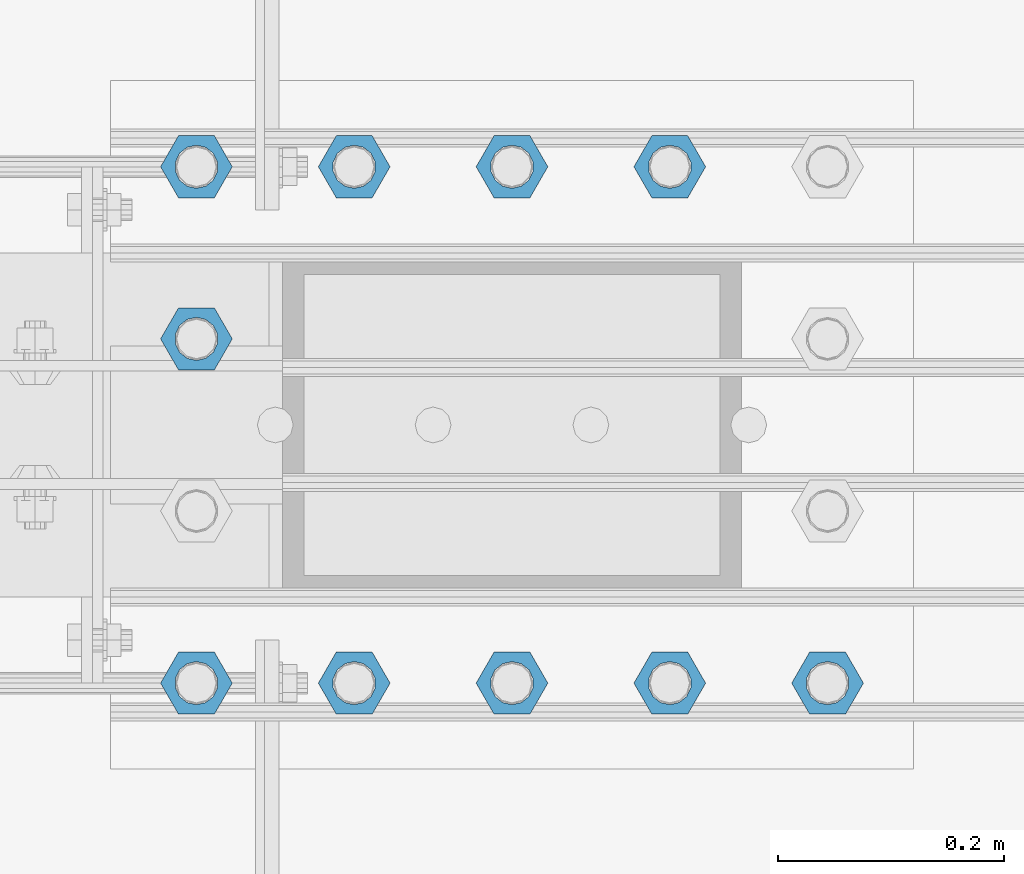
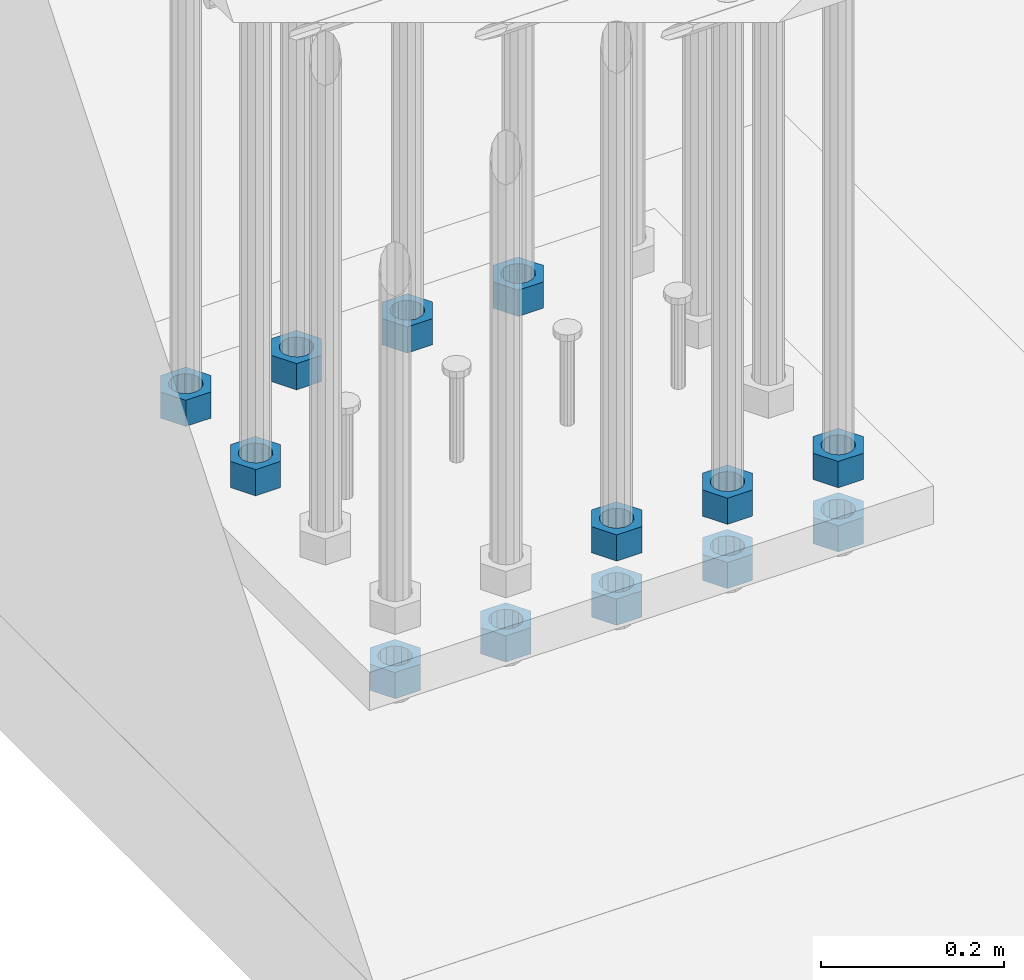
# One storey, part 1376 of 1876: 13 beams, 1 element without a shape of its own.
"""IFC2X3 building model written with IfcOpenShell, lengths in millimetres."""

from ifc_helpers import new_model, si_unit, frame, origin_with_axes, place, context, subcontext, project, spatial, faceted_brep, material, type_object, element, aggregate, save


model = new_model("IFC2X3")

# Units and contexts
model_context = context("Model", 3, precision=1e-05, world=origin_with_axes())
body_context = subcontext(model_context, "Body", "Model", "MODEL_VIEW")
ifc_project = project(units=[si_unit("LENGTHUNIT", "METRE", prefix="MILLI"), si_unit("AREAUNIT", "SQUARE_METRE"), si_unit("VOLUMEUNIT", "CUBIC_METRE"), si_unit("MASSUNIT", "GRAM", prefix="KILO"), si_unit("TIMEUNIT", "SECOND"), si_unit("PLANEANGLEUNIT", "RADIAN"), si_unit("SOLIDANGLEUNIT", "STERADIAN"), si_unit("THERMODYNAMICTEMPERATUREUNIT", "DEGREE_CELSIUS"), si_unit("LUMINOUSINTENSITYUNIT", "LUMEN")], contexts=[model_context])

# Site, building, storey
site_placement = place(None, origin_with_axes())
site = spatial("IfcSite", under=ifc_project, at=site_placement, CompositionType="ELEMENT")
building_placement = place(site_placement, origin_with_axes())
building = spatial("IfcBuilding", under=site, at=building_placement, Name="Undefined", CompositionType="ELEMENT")
storey_placement = place(building_placement, origin_with_axes())
storey = spatial("IfcBuildingStorey", under=building, at=storey_placement, Name="Undefined", CompositionType="ELEMENT", Elevation=0.0)

# Assembly, beams
assembly_placement = place(storey_placement, origin_with_axes())
assembly = element("IfcElementAssembly", 1, at=assembly_placement, inside=storey, Name="PLATE", AssemblyPlace="NOTDEFINED", PredefinedType="RIGID_FRAME")
ifc_material = material(Name="STEEL/A563")
beam_type = type_object("IfcBeamType", Name="1-3/8_HEAVY_HEX_NUT", PredefinedType="NOTDEFINED")
beam_1_placement = place(assembly_placement, frame((371.474990844727, -10541.0, -701.675000762939), z_axis=(0.0, -1.0, 0.0), x_axis=(0.0, 0.0, -1.0)))
beam_1 = element("IfcBeam", 2, at=beam_1_placement, type_object=beam_type, material=ifc_material, Name="NUT", ObjectType="1-3/8_HEAVY_HEX_NUT", context=body_context, shape_type="Brep", body=[
    faceted_brep([(0.0, -31.75, 0.0), (0.0, -15.8800001144409, -27.5), (34.925, -15.8800001144409, -27.5), (34.925, -31.75, 0.0), (0.0, 15.8800001144409, -27.5), (34.925, 15.8800001144409, -27.5), (0.0, 31.75, 0.0), (34.925, 31.75, 0.0), (0.0, 15.8800001144409, 27.5), (34.925, 15.8800001144409, 27.5), (0.0, -15.8800001144409, 27.5), (34.925, -15.8800001144409, 27.5), (0.0, 0.0, 19.0499999999993), (0.0, 8.2654848991624, 17.1634562461559), (34.925, 8.26548489916252, 17.163456246155), (34.925, 0.0, 19.0499992370605), (0.0, 14.8938891445259, 11.8774802497237), (34.925, 14.8938891445259, 11.8774802497246), (0.0, 18.5723759832526, 4.2390236220981), (34.925, 18.5723759832528, 4.23902362209628), (0.0, 18.5723759832526, -4.2390236220981), (34.925, 18.5723759832528, -4.23902362209628), (0.0, 14.8938891445259, -11.8774802497237), (34.925, 14.8938891445259, -11.8774802497246), (0.0, 8.2654848991624, -17.1634562461568), (34.925, 8.26548489916252, -17.163456246155), (0.0, 0.0, -19.05), (34.925, 0.0, -19.0499992370605), (0.0, -8.2654848991624, -17.1634562461559), (34.925, -8.26548489916252, -17.163456246155), (0.0, -14.8938891445259, -11.8774802497237), (34.925, -14.8938891445259, -11.8774802497246), (0.0, -18.5723759832526, -4.2390236220981), (34.925, -18.5723759832528, -4.23902362209628), (0.0, -18.5723759832526, 4.2390236220981), (34.925, -18.5723759832528, 4.23902362209628), (0.0, -14.8938891445259, 11.8774802497237), (34.925, -14.8938891445259, 11.8774802497246), (0.0, -8.2654848991624, 17.1634562461568), (34.925, -8.26548489916252, 17.163456246155)], [[[0, 1, 2, 3]], [[1, 4, 5, 2]], [[4, 6, 7, 5]], [[6, 8, 9, 7]], [[8, 10, 11, 9]], [[10, 0, 3, 11]], [[12, 13, 14, 15]], [[13, 16, 17, 14]], [[16, 18, 19, 17]], [[18, 20, 21, 19]], [[20, 22, 23, 21]], [[22, 24, 25, 23]], [[24, 26, 27, 25]], [[26, 28, 29, 27]], [[28, 30, 31, 29]], [[30, 32, 33, 31]], [[32, 34, 35, 33]], [[34, 36, 37, 35]], [[36, 38, 39, 37]], [[38, 12, 15, 39]], [[5, 7, 9, 11, 3, 2], [17, 19, 21, 23, 25, 27, 29, 31, 33, 35, 37, 39, 15, 14]], [[10, 8, 6, 4, 1, 0], [38, 36, 34, 32, 30, 28, 26, 24, 22, 20, 18, 16, 13, 12]]]),
])
beam_2_placement = place(assembly_placement, frame((231.774990844727, -10541.0, -701.675000762939), z_axis=(0.0, -1.0, 0.0), x_axis=(0.0, 0.0, -1.0)))
beam_2 = element("IfcBeam", 3, at=beam_2_placement, type_object=beam_type, material=ifc_material, Name="NUT", ObjectType="1-3/8_HEAVY_HEX_NUT", context=body_context, shape_type="Brep", body=[
    faceted_brep([(0.0, -31.75, 0.0), (0.0, -15.8800001144409, -27.5), (34.925, -15.8800001144409, -27.5), (34.925, -31.75, 0.0), (0.0, 15.8800001144409, -27.5), (34.925, 15.8800001144409, -27.5), (0.0, 31.75, 0.0), (34.925, 31.75, 0.0), (0.0, 15.8800001144409, 27.5), (34.925, 15.8800001144409, 27.5), (0.0, -15.8800001144409, 27.5), (34.925, -15.8800001144409, 27.5), (0.0, 0.0, 19.0499999999993), (0.0, 8.2654848991624, 17.1634562461559), (34.925, 8.26548489916252, 17.163456246155), (34.925, 0.0, 19.0499992370605), (0.0, 14.8938891445259, 11.8774802497237), (34.925, 14.8938891445259, 11.8774802497246), (0.0, 18.5723759832526, 4.2390236220981), (34.925, 18.5723759832528, 4.23902362209628), (0.0, 18.5723759832526, -4.2390236220981), (34.925, 18.5723759832528, -4.23902362209628), (0.0, 14.8938891445259, -11.8774802497237), (34.925, 14.8938891445259, -11.8774802497246), (0.0, 8.2654848991624, -17.1634562461568), (34.925, 8.26548489916252, -17.163456246155), (0.0, 0.0, -19.05), (34.925, 0.0, -19.0499992370605), (0.0, -8.2654848991624, -17.1634562461559), (34.925, -8.26548489916252, -17.163456246155), (0.0, -14.8938891445259, -11.8774802497237), (34.925, -14.8938891445259, -11.8774802497246), (0.0, -18.5723759832526, -4.2390236220981), (34.925, -18.5723759832528, -4.23902362209628), (0.0, -18.5723759832526, 4.2390236220981), (34.925, -18.5723759832528, 4.23902362209628), (0.0, -14.8938891445259, 11.8774802497237), (34.925, -14.8938891445259, 11.8774802497246), (0.0, -8.2654848991624, 17.1634562461568), (34.925, -8.26548489916252, 17.163456246155)], [[[0, 1, 2, 3]], [[1, 4, 5, 2]], [[4, 6, 7, 5]], [[6, 8, 9, 7]], [[8, 10, 11, 9]], [[10, 0, 3, 11]], [[12, 13, 14, 15]], [[13, 16, 17, 14]], [[16, 18, 19, 17]], [[18, 20, 21, 19]], [[20, 22, 23, 21]], [[22, 24, 25, 23]], [[24, 26, 27, 25]], [[26, 28, 29, 27]], [[28, 30, 31, 29]], [[30, 32, 33, 31]], [[32, 34, 35, 33]], [[34, 36, 37, 35]], [[36, 38, 39, 37]], [[38, 12, 15, 39]], [[5, 7, 9, 11, 3, 2], [17, 19, 21, 23, 25, 27, 29, 31, 33, 35, 37, 39, 15, 14]], [[10, 8, 6, 4, 1, 0], [38, 36, 34, 32, 30, 28, 26, 24, 22, 20, 18, 16, 13, 12]]]),
])
beam_3_placement = place(assembly_placement, frame((92.0749908447272, -10541.0, -701.675000762939), z_axis=(0.0, -1.0, 0.0), x_axis=(0.0, 0.0, -1.0)))
beam_3 = element("IfcBeam", 4, at=beam_3_placement, type_object=beam_type, material=ifc_material, Name="NUT", ObjectType="1-3/8_HEAVY_HEX_NUT", context=body_context, shape_type="Brep", body=[
    faceted_brep([(0.0, -31.75, 0.0), (0.0, -15.8800001144409, -27.5), (34.925, -15.8800001144409, -27.5), (34.925, -31.75, 0.0), (0.0, 15.8800001144409, -27.5), (34.925, 15.8800001144409, -27.5), (0.0, 31.75, 0.0), (34.925, 31.75, 0.0), (0.0, 15.8800001144409, 27.5), (34.925, 15.8800001144409, 27.5), (0.0, -15.8800001144409, 27.5), (34.925, -15.8800001144409, 27.5), (0.0, 0.0, 19.0499999999993), (0.0, 8.2654848991624, 17.1634562461559), (34.925, 8.26548489916252, 17.163456246155), (34.925, 0.0, 19.0499992370605), (0.0, 14.8938891445259, 11.8774802497237), (34.925, 14.8938891445259, 11.8774802497246), (0.0, 18.5723759832526, 4.2390236220981), (34.925, 18.5723759832528, 4.23902362209628), (0.0, 18.5723759832526, -4.2390236220981), (34.925, 18.5723759832528, -4.23902362209628), (0.0, 14.8938891445259, -11.8774802497237), (34.925, 14.8938891445259, -11.8774802497246), (0.0, 8.2654848991624, -17.1634562461568), (34.925, 8.26548489916252, -17.163456246155), (0.0, 0.0, -19.05), (34.925, 0.0, -19.0499992370605), (0.0, -8.2654848991624, -17.1634562461559), (34.925, -8.26548489916252, -17.163456246155), (0.0, -14.8938891445259, -11.8774802497237), (34.925, -14.8938891445259, -11.8774802497246), (0.0, -18.5723759832526, -4.2390236220981), (34.925, -18.5723759832528, -4.23902362209628), (0.0, -18.5723759832526, 4.2390236220981), (34.925, -18.5723759832528, 4.23902362209628), (0.0, -14.8938891445259, 11.8774802497237), (34.925, -14.8938891445259, 11.8774802497246), (0.0, -8.2654848991624, 17.1634562461568), (34.925, -8.26548489916252, 17.163456246155)], [[[0, 1, 2, 3]], [[1, 4, 5, 2]], [[4, 6, 7, 5]], [[6, 8, 9, 7]], [[8, 10, 11, 9]], [[10, 0, 3, 11]], [[12, 13, 14, 15]], [[13, 16, 17, 14]], [[16, 18, 19, 17]], [[18, 20, 21, 19]], [[20, 22, 23, 21]], [[22, 24, 25, 23]], [[24, 26, 27, 25]], [[26, 28, 29, 27]], [[28, 30, 31, 29]], [[30, 32, 33, 31]], [[32, 34, 35, 33]], [[34, 36, 37, 35]], [[36, 38, 39, 37]], [[38, 12, 15, 39]], [[5, 7, 9, 11, 3, 2], [17, 19, 21, 23, 25, 27, 29, 31, 33, 35, 37, 39, 15, 14]], [[10, 8, 6, 4, 1, 0], [38, 36, 34, 32, 30, 28, 26, 24, 22, 20, 18, 16, 13, 12]]]),
])
beam_4_placement = place(assembly_placement, frame((-47.6250091552728, -10541.0, -701.675000762939), z_axis=(0.0, -1.0, 0.0), x_axis=(0.0, 0.0, -1.0)))
beam_4 = element("IfcBeam", 5, at=beam_4_placement, type_object=beam_type, material=ifc_material, Name="NUT", ObjectType="1-3/8_HEAVY_HEX_NUT", context=body_context, shape_type="Brep", body=[
    faceted_brep([(0.0, -31.75, 0.0), (0.0, -15.8800001144409, -27.5), (34.925, -15.8800001144409, -27.5), (34.925, -31.75, 0.0), (0.0, 15.8800001144409, -27.5), (34.925, 15.8800001144409, -27.5), (0.0, 31.75, 0.0), (34.925, 31.75, 0.0), (0.0, 15.8800001144409, 27.5), (34.925, 15.8800001144409, 27.5), (0.0, -15.8800001144409, 27.5), (34.925, -15.8800001144409, 27.5), (0.0, 0.0, 19.0499999999993), (0.0, 8.2654848991624, 17.1634562461559), (34.925, 8.26548489916252, 17.163456246155), (34.925, 0.0, 19.0499992370605), (0.0, 14.8938891445259, 11.8774802497237), (34.925, 14.8938891445259, 11.8774802497246), (0.0, 18.5723759832526, 4.2390236220981), (34.925, 18.5723759832528, 4.23902362209628), (0.0, 18.5723759832526, -4.2390236220981), (34.925, 18.5723759832528, -4.23902362209628), (0.0, 14.8938891445259, -11.8774802497237), (34.925, 14.8938891445259, -11.8774802497246), (0.0, 8.2654848991624, -17.1634562461568), (34.925, 8.26548489916252, -17.163456246155), (0.0, 0.0, -19.05), (34.925, 0.0, -19.0499992370605), (0.0, -8.2654848991624, -17.1634562461559), (34.925, -8.26548489916252, -17.163456246155), (0.0, -14.8938891445259, -11.8774802497237), (34.925, -14.8938891445259, -11.8774802497246), (0.0, -18.5723759832526, -4.2390236220981), (34.925, -18.5723759832528, -4.23902362209628), (0.0, -18.5723759832526, 4.2390236220981), (34.925, -18.5723759832528, 4.23902362209628), (0.0, -14.8938891445259, 11.8774802497237), (34.925, -14.8938891445259, 11.8774802497246), (0.0, -8.2654848991624, 17.1634562461568), (34.925, -8.26548489916252, 17.163456246155)], [[[0, 1, 2, 3]], [[1, 4, 5, 2]], [[4, 6, 7, 5]], [[6, 8, 9, 7]], [[8, 10, 11, 9]], [[10, 0, 3, 11]], [[12, 13, 14, 15]], [[13, 16, 17, 14]], [[16, 18, 19, 17]], [[18, 20, 21, 19]], [[20, 22, 23, 21]], [[22, 24, 25, 23]], [[24, 26, 27, 25]], [[26, 28, 29, 27]], [[28, 30, 31, 29]], [[30, 32, 33, 31]], [[32, 34, 35, 33]], [[34, 36, 37, 35]], [[36, 38, 39, 37]], [[38, 12, 15, 39]], [[5, 7, 9, 11, 3, 2], [17, 19, 21, 23, 25, 27, 29, 31, 33, 35, 37, 39, 15, 14]], [[10, 8, 6, 4, 1, 0], [38, 36, 34, 32, 30, 28, 26, 24, 22, 20, 18, 16, 13, 12]]]),
])
beam_5_placement = place(assembly_placement, frame((-47.6250091552728, -10693.399991862, -701.675000762939), z_axis=(0.0, -1.0, 0.0), x_axis=(0.0, 0.0, -1.0)))
beam_5 = element("IfcBeam", 6, at=beam_5_placement, type_object=beam_type, material=ifc_material, Name="NUT", ObjectType="1-3/8_HEAVY_HEX_NUT", context=body_context, shape_type="Brep", body=[
    faceted_brep([(0.0, -31.75, 0.0), (0.0, -15.8800001144409, -27.5), (34.925, -15.8800001144409, -27.5), (34.925, -31.75, 0.0), (0.0, 15.8800001144409, -27.5), (34.925, 15.8800001144409, -27.5), (0.0, 31.75, 0.0), (34.925, 31.75, 0.0), (0.0, 15.8800001144409, 27.5), (34.925, 15.8800001144409, 27.5), (0.0, -15.8800001144409, 27.5), (34.925, -15.8800001144409, 27.5), (0.0, 0.0, 19.0499999999993), (0.0, 8.2654848991624, 17.1634562461559), (34.925, 8.26548489916252, 17.163456246155), (34.925, 0.0, 19.0499992370605), (0.0, 14.8938891445259, 11.8774802497237), (34.925, 14.8938891445259, 11.8774802497246), (0.0, 18.5723759832526, 4.2390236220981), (34.925, 18.5723759832528, 4.23902362209628), (0.0, 18.5723759832526, -4.2390236220981), (34.925, 18.5723759832528, -4.23902362209628), (0.0, 14.8938891445259, -11.8774802497237), (34.925, 14.8938891445259, -11.8774802497246), (0.0, 8.2654848991624, -17.1634562461568), (34.925, 8.26548489916252, -17.163456246155), (0.0, 0.0, -19.05), (34.925, 0.0, -19.0499992370605), (0.0, -8.2654848991624, -17.1634562461559), (34.925, -8.26548489916252, -17.163456246155), (0.0, -14.8938891445259, -11.8774802497237), (34.925, -14.8938891445259, -11.8774802497246), (0.0, -18.5723759832526, -4.2390236220981), (34.925, -18.5723759832528, -4.23902362209628), (0.0, -18.5723759832526, 4.2390236220981), (34.925, -18.5723759832528, 4.23902362209628), (0.0, -14.8938891445259, 11.8774802497237), (34.925, -14.8938891445259, 11.8774802497246), (0.0, -8.2654848991624, 17.1634562461568), (34.925, -8.26548489916252, 17.163456246155)], [[[0, 1, 2, 3]], [[1, 4, 5, 2]], [[4, 6, 7, 5]], [[6, 8, 9, 7]], [[8, 10, 11, 9]], [[10, 0, 3, 11]], [[12, 13, 14, 15]], [[13, 16, 17, 14]], [[16, 18, 19, 17]], [[18, 20, 21, 19]], [[20, 22, 23, 21]], [[22, 24, 25, 23]], [[24, 26, 27, 25]], [[26, 28, 29, 27]], [[28, 30, 31, 29]], [[30, 32, 33, 31]], [[32, 34, 35, 33]], [[34, 36, 37, 35]], [[36, 38, 39, 37]], [[38, 12, 15, 39]], [[5, 7, 9, 11, 3, 2], [17, 19, 21, 23, 25, 27, 29, 31, 33, 35, 37, 39, 15, 14]], [[10, 8, 6, 4, 1, 0], [38, 36, 34, 32, 30, 28, 26, 24, 22, 20, 18, 16, 13, 12]]]),
])
beam_6_placement = place(assembly_placement, frame((231.774990844727, -10998.1999755859, -701.675000762939), z_axis=(0.0, -1.0, 0.0), x_axis=(0.0, 0.0, -1.0)))
beam_6 = element("IfcBeam", 7, at=beam_6_placement, type_object=beam_type, material=ifc_material, Name="NUT", ObjectType="1-3/8_HEAVY_HEX_NUT", context=body_context, shape_type="Brep", body=[
    faceted_brep([(0.0, -31.75, 0.0), (0.0, -15.8800001144409, -27.5), (34.925, -15.8800001144409, -27.5), (34.925, -31.75, 0.0), (0.0, 15.8800001144409, -27.5), (34.925, 15.8800001144409, -27.5), (0.0, 31.75, 0.0), (34.925, 31.75, 0.0), (0.0, 15.8800001144409, 27.5), (34.925, 15.8800001144409, 27.5), (0.0, -15.8800001144409, 27.5), (34.925, -15.8800001144409, 27.5), (0.0, 0.0, 19.0499999999993), (0.0, 8.2654848991624, 17.1634562461559), (34.925, 8.26548489916252, 17.163456246155), (34.925, 0.0, 19.0499992370605), (0.0, 14.8938891445259, 11.8774802497237), (34.925, 14.8938891445259, 11.8774802497246), (0.0, 18.5723759832526, 4.2390236220981), (34.925, 18.5723759832528, 4.23902362209628), (0.0, 18.5723759832526, -4.2390236220981), (34.925, 18.5723759832528, -4.23902362209628), (0.0, 14.8938891445259, -11.8774802497237), (34.925, 14.8938891445259, -11.8774802497246), (0.0, 8.2654848991624, -17.1634562461568), (34.925, 8.26548489916252, -17.163456246155), (0.0, 0.0, -19.05), (34.925, 0.0, -19.0499992370605), (0.0, -8.2654848991624, -17.1634562461559), (34.925, -8.26548489916252, -17.163456246155), (0.0, -14.8938891445259, -11.8774802497237), (34.925, -14.8938891445259, -11.8774802497246), (0.0, -18.5723759832526, -4.2390236220981), (34.925, -18.5723759832528, -4.23902362209628), (0.0, -18.5723759832526, 4.2390236220981), (34.925, -18.5723759832528, 4.23902362209628), (0.0, -14.8938891445259, 11.8774802497237), (34.925, -14.8938891445259, 11.8774802497246), (0.0, -8.2654848991624, 17.1634562461568), (34.925, -8.26548489916252, 17.163456246155)], [[[0, 1, 2, 3]], [[1, 4, 5, 2]], [[4, 6, 7, 5]], [[6, 8, 9, 7]], [[8, 10, 11, 9]], [[10, 0, 3, 11]], [[12, 13, 14, 15]], [[13, 16, 17, 14]], [[16, 18, 19, 17]], [[18, 20, 21, 19]], [[20, 22, 23, 21]], [[22, 24, 25, 23]], [[24, 26, 27, 25]], [[26, 28, 29, 27]], [[28, 30, 31, 29]], [[30, 32, 33, 31]], [[32, 34, 35, 33]], [[34, 36, 37, 35]], [[36, 38, 39, 37]], [[38, 12, 15, 39]], [[5, 7, 9, 11, 3, 2], [17, 19, 21, 23, 25, 27, 29, 31, 33, 35, 37, 39, 15, 14]], [[10, 8, 6, 4, 1, 0], [38, 36, 34, 32, 30, 28, 26, 24, 22, 20, 18, 16, 13, 12]]]),
])
beam_7_placement = place(assembly_placement, frame((371.474990844727, -10998.1999755859, -701.675000762939), z_axis=(0.0, -1.0, 0.0), x_axis=(0.0, 0.0, -1.0)))
beam_7 = element("IfcBeam", 8, at=beam_7_placement, type_object=beam_type, material=ifc_material, Name="NUT", ObjectType="1-3/8_HEAVY_HEX_NUT", context=body_context, shape_type="Brep", body=[
    faceted_brep([(0.0, -31.75, 0.0), (0.0, -15.8800001144409, -27.5), (34.925, -15.8800001144409, -27.5), (34.925, -31.75, 0.0), (0.0, 15.8800001144409, -27.5), (34.925, 15.8800001144409, -27.5), (0.0, 31.75, 0.0), (34.925, 31.75, 0.0), (0.0, 15.8800001144409, 27.5), (34.925, 15.8800001144409, 27.5), (0.0, -15.8800001144409, 27.5), (34.925, -15.8800001144409, 27.5), (0.0, 0.0, 19.0499999999993), (0.0, 8.2654848991624, 17.1634562461559), (34.925, 8.26548489916252, 17.163456246155), (34.925, 0.0, 19.0499992370605), (0.0, 14.8938891445259, 11.8774802497237), (34.925, 14.8938891445259, 11.8774802497246), (0.0, 18.5723759832526, 4.2390236220981), (34.925, 18.5723759832528, 4.23902362209628), (0.0, 18.5723759832526, -4.2390236220981), (34.925, 18.5723759832528, -4.23902362209628), (0.0, 14.8938891445259, -11.8774802497237), (34.925, 14.8938891445259, -11.8774802497246), (0.0, 8.2654848991624, -17.1634562461568), (34.925, 8.26548489916252, -17.163456246155), (0.0, 0.0, -19.05), (34.925, 0.0, -19.0499992370605), (0.0, -8.2654848991624, -17.1634562461559), (34.925, -8.26548489916252, -17.163456246155), (0.0, -14.8938891445259, -11.8774802497237), (34.925, -14.8938891445259, -11.8774802497246), (0.0, -18.5723759832526, -4.2390236220981), (34.925, -18.5723759832528, -4.23902362209628), (0.0, -18.5723759832526, 4.2390236220981), (34.925, -18.5723759832528, 4.23902362209628), (0.0, -14.8938891445259, 11.8774802497237), (34.925, -14.8938891445259, 11.8774802497246), (0.0, -8.2654848991624, 17.1634562461568), (34.925, -8.26548489916252, 17.163456246155)], [[[0, 1, 2, 3]], [[1, 4, 5, 2]], [[4, 6, 7, 5]], [[6, 8, 9, 7]], [[8, 10, 11, 9]], [[10, 0, 3, 11]], [[12, 13, 14, 15]], [[13, 16, 17, 14]], [[16, 18, 19, 17]], [[18, 20, 21, 19]], [[20, 22, 23, 21]], [[22, 24, 25, 23]], [[24, 26, 27, 25]], [[26, 28, 29, 27]], [[28, 30, 31, 29]], [[30, 32, 33, 31]], [[32, 34, 35, 33]], [[34, 36, 37, 35]], [[36, 38, 39, 37]], [[38, 12, 15, 39]], [[5, 7, 9, 11, 3, 2], [17, 19, 21, 23, 25, 27, 29, 31, 33, 35, 37, 39, 15, 14]], [[10, 8, 6, 4, 1, 0], [38, 36, 34, 32, 30, 28, 26, 24, 22, 20, 18, 16, 13, 12]]]),
])
beam_8_placement = place(assembly_placement, frame((511.175003051758, -10998.1999755859, -701.675000762939), z_axis=(0.0, -1.0, 0.0), x_axis=(0.0, 0.0, -1.0)))
beam_8 = element("IfcBeam", 9, at=beam_8_placement, type_object=beam_type, material=ifc_material, Name="NUT", ObjectType="1-3/8_HEAVY_HEX_NUT", context=body_context, shape_type="Brep", body=[
    faceted_brep([(0.0, -31.75, 0.0), (0.0, -15.8800001144409, -27.5), (34.925, -15.8800001144409, -27.5), (34.925, -31.75, 0.0), (0.0, 15.8800001144409, -27.5), (34.925, 15.8800001144409, -27.5), (0.0, 31.75, 0.0), (34.925, 31.75, 0.0), (0.0, 15.8800001144409, 27.5), (34.925, 15.8800001144409, 27.5), (0.0, -15.8800001144409, 27.5), (34.925, -15.8800001144409, 27.5), (0.0, 0.0, 19.0499999999993), (0.0, 8.2654848991624, 17.1634562461559), (34.925, 8.26548489916252, 17.163456246155), (34.925, 0.0, 19.0499992370605), (0.0, 14.8938891445259, 11.8774802497237), (34.925, 14.8938891445259, 11.8774802497246), (0.0, 18.5723759832526, 4.2390236220981), (34.925, 18.5723759832528, 4.23902362209628), (0.0, 18.5723759832526, -4.2390236220981), (34.925, 18.5723759832528, -4.23902362209628), (0.0, 14.8938891445259, -11.8774802497237), (34.925, 14.8938891445259, -11.8774802497246), (0.0, 8.2654848991624, -17.1634562461568), (34.925, 8.26548489916252, -17.163456246155), (0.0, 0.0, -19.05), (34.925, 0.0, -19.0499992370605), (0.0, -8.2654848991624, -17.1634562461559), (34.925, -8.26548489916252, -17.163456246155), (0.0, -14.8938891445259, -11.8774802497237), (34.925, -14.8938891445259, -11.8774802497246), (0.0, -18.5723759832526, -4.2390236220981), (34.925, -18.5723759832528, -4.23902362209628), (0.0, -18.5723759832526, 4.2390236220981), (34.925, -18.5723759832528, 4.23902362209628), (0.0, -14.8938891445259, 11.8774802497237), (34.925, -14.8938891445259, 11.8774802497246), (0.0, -8.2654848991624, 17.1634562461568), (34.925, -8.26548489916252, 17.163456246155)], [[[0, 1, 2, 3]], [[1, 4, 5, 2]], [[4, 6, 7, 5]], [[6, 8, 9, 7]], [[8, 10, 11, 9]], [[10, 0, 3, 11]], [[12, 13, 14, 15]], [[13, 16, 17, 14]], [[16, 18, 19, 17]], [[18, 20, 21, 19]], [[20, 22, 23, 21]], [[22, 24, 25, 23]], [[24, 26, 27, 25]], [[26, 28, 29, 27]], [[28, 30, 31, 29]], [[30, 32, 33, 31]], [[32, 34, 35, 33]], [[34, 36, 37, 35]], [[36, 38, 39, 37]], [[38, 12, 15, 39]], [[5, 7, 9, 11, 3, 2], [17, 19, 21, 23, 25, 27, 29, 31, 33, 35, 37, 39, 15, 14]], [[10, 8, 6, 4, 1, 0], [38, 36, 34, 32, 30, 28, 26, 24, 22, 20, 18, 16, 13, 12]]]),
])
beam_9_placement = place(assembly_placement, frame((-47.625012207031, -10998.1999755859, -787.4), z_axis=(0.0, -1.0, 0.0), x_axis=(0.0, 0.0, -1.0)))
beam_9 = element("IfcBeam", 10, at=beam_9_placement, type_object=beam_type, material=ifc_material, Name="NUT", ObjectType="1-3/8_HEAVY_HEX_NUT", context=body_context, shape_type="Brep", body=[
    faceted_brep([(0.0, -31.75, 0.0), (0.0, -15.8800001144409, -27.5), (34.925, -15.8800001144409, -27.5), (34.925, -31.75, 0.0), (0.0, 15.8800001144409, -27.5), (34.925, 15.8800001144409, -27.5), (0.0, 31.75, 0.0), (34.925, 31.75, 0.0), (0.0, 15.8800001144409, 27.5), (34.925, 15.8800001144409, 27.5), (0.0, -15.8800001144409, 27.5), (34.925, -15.8800001144409, 27.5), (0.0, 0.0, 19.0499999999993), (0.0, 8.2654848991624, 17.1634562461559), (34.925, 8.26548489916252, 17.163456246155), (34.925, 0.0, 19.0499992370605), (0.0, 14.8938891445259, 11.8774802497237), (34.925, 14.8938891445259, 11.8774802497246), (0.0, 18.5723759832526, 4.2390236220981), (34.925, 18.5723759832528, 4.23902362209628), (0.0, 18.5723759832526, -4.2390236220981), (34.925, 18.5723759832528, -4.23902362209628), (0.0, 14.8938891445259, -11.8774802497237), (34.925, 14.8938891445259, -11.8774802497246), (0.0, 8.2654848991624, -17.1634562461568), (34.925, 8.26548489916252, -17.163456246155), (0.0, 0.0, -19.05), (34.925, 0.0, -19.0499992370605), (0.0, -8.2654848991624, -17.1634562461559), (34.925, -8.26548489916252, -17.163456246155), (0.0, -14.8938891445259, -11.8774802497237), (34.925, -14.8938891445259, -11.8774802497246), (0.0, -18.5723759832526, -4.2390236220981), (34.925, -18.5723759832528, -4.23902362209628), (0.0, -18.5723759832526, 4.2390236220981), (34.925, -18.5723759832528, 4.23902362209628), (0.0, -14.8938891445259, 11.8774802497237), (34.925, -14.8938891445259, 11.8774802497246), (0.0, -8.2654848991624, 17.1634562461568), (34.925, -8.26548489916252, 17.163456246155)], [[[0, 1, 2, 3]], [[1, 4, 5, 2]], [[4, 6, 7, 5]], [[6, 8, 9, 7]], [[8, 10, 11, 9]], [[10, 0, 3, 11]], [[12, 13, 14, 15]], [[13, 16, 17, 14]], [[16, 18, 19, 17]], [[18, 20, 21, 19]], [[20, 22, 23, 21]], [[22, 24, 25, 23]], [[24, 26, 27, 25]], [[26, 28, 29, 27]], [[28, 30, 31, 29]], [[30, 32, 33, 31]], [[32, 34, 35, 33]], [[34, 36, 37, 35]], [[36, 38, 39, 37]], [[38, 12, 15, 39]], [[5, 7, 9, 11, 3, 2], [17, 19, 21, 23, 25, 27, 29, 31, 33, 35, 37, 39, 15, 14]], [[10, 8, 6, 4, 1, 0], [38, 36, 34, 32, 30, 28, 26, 24, 22, 20, 18, 16, 13, 12]]]),
])
beam_10_placement = place(assembly_placement, frame((92.074987792969, -10998.1999755859, -787.4), z_axis=(0.0, -1.0, 0.0), x_axis=(0.0, 0.0, -1.0)))
beam_10 = element("IfcBeam", 11, at=beam_10_placement, type_object=beam_type, material=ifc_material, Name="NUT", ObjectType="1-3/8_HEAVY_HEX_NUT", context=body_context, shape_type="Brep", body=[
    faceted_brep([(0.0, -31.75, 0.0), (0.0, -15.8800001144409, -27.5), (34.925, -15.8800001144409, -27.5), (34.925, -31.75, 0.0), (0.0, 15.8800001144409, -27.5), (34.925, 15.8800001144409, -27.5), (0.0, 31.75, 0.0), (34.925, 31.75, 0.0), (0.0, 15.8800001144409, 27.5), (34.925, 15.8800001144409, 27.5), (0.0, -15.8800001144409, 27.5), (34.925, -15.8800001144409, 27.5), (0.0, 0.0, 19.0499999999993), (0.0, 8.2654848991624, 17.1634562461559), (34.925, 8.26548489916252, 17.163456246155), (34.925, 0.0, 19.0499992370605), (0.0, 14.8938891445259, 11.8774802497237), (34.925, 14.8938891445259, 11.8774802497246), (0.0, 18.5723759832526, 4.2390236220981), (34.925, 18.5723759832528, 4.23902362209628), (0.0, 18.5723759832526, -4.2390236220981), (34.925, 18.5723759832528, -4.23902362209628), (0.0, 14.8938891445259, -11.8774802497237), (34.925, 14.8938891445259, -11.8774802497246), (0.0, 8.2654848991624, -17.1634562461568), (34.925, 8.26548489916252, -17.163456246155), (0.0, 0.0, -19.05), (34.925, 0.0, -19.0499992370605), (0.0, -8.2654848991624, -17.1634562461559), (34.925, -8.26548489916252, -17.163456246155), (0.0, -14.8938891445259, -11.8774802497237), (34.925, -14.8938891445259, -11.8774802497246), (0.0, -18.5723759832526, -4.2390236220981), (34.925, -18.5723759832528, -4.23902362209628), (0.0, -18.5723759832526, 4.2390236220981), (34.925, -18.5723759832528, 4.23902362209628), (0.0, -14.8938891445259, 11.8774802497237), (34.925, -14.8938891445259, 11.8774802497246), (0.0, -8.2654848991624, 17.1634562461568), (34.925, -8.26548489916252, 17.163456246155)], [[[0, 1, 2, 3]], [[1, 4, 5, 2]], [[4, 6, 7, 5]], [[6, 8, 9, 7]], [[8, 10, 11, 9]], [[10, 0, 3, 11]], [[12, 13, 14, 15]], [[13, 16, 17, 14]], [[16, 18, 19, 17]], [[18, 20, 21, 19]], [[20, 22, 23, 21]], [[22, 24, 25, 23]], [[24, 26, 27, 25]], [[26, 28, 29, 27]], [[28, 30, 31, 29]], [[30, 32, 33, 31]], [[32, 34, 35, 33]], [[34, 36, 37, 35]], [[36, 38, 39, 37]], [[38, 12, 15, 39]], [[5, 7, 9, 11, 3, 2], [17, 19, 21, 23, 25, 27, 29, 31, 33, 35, 37, 39, 15, 14]], [[10, 8, 6, 4, 1, 0], [38, 36, 34, 32, 30, 28, 26, 24, 22, 20, 18, 16, 13, 12]]]),
])
beam_11_placement = place(assembly_placement, frame((231.774987792969, -10998.1999755859, -787.4), z_axis=(0.0, -1.0, 0.0), x_axis=(0.0, 0.0, -1.0)))
beam_11 = element("IfcBeam", 12, at=beam_11_placement, type_object=beam_type, material=ifc_material, Name="NUT", ObjectType="1-3/8_HEAVY_HEX_NUT", context=body_context, shape_type="Brep", body=[
    faceted_brep([(0.0, -31.75, 0.0), (0.0, -15.8800001144409, -27.5), (34.925, -15.8800001144409, -27.5), (34.925, -31.75, 0.0), (0.0, 15.8800001144409, -27.5), (34.925, 15.8800001144409, -27.5), (0.0, 31.75, 0.0), (34.925, 31.75, 0.0), (0.0, 15.8800001144409, 27.5), (34.925, 15.8800001144409, 27.5), (0.0, -15.8800001144409, 27.5), (34.925, -15.8800001144409, 27.5), (0.0, 0.0, 19.0499999999993), (0.0, 8.2654848991624, 17.1634562461559), (34.925, 8.26548489916252, 17.163456246155), (34.925, 0.0, 19.0499992370605), (0.0, 14.8938891445259, 11.8774802497237), (34.925, 14.8938891445259, 11.8774802497246), (0.0, 18.5723759832526, 4.2390236220981), (34.925, 18.5723759832528, 4.23902362209628), (0.0, 18.5723759832526, -4.2390236220981), (34.925, 18.5723759832528, -4.23902362209628), (0.0, 14.8938891445259, -11.8774802497237), (34.925, 14.8938891445259, -11.8774802497246), (0.0, 8.2654848991624, -17.1634562461568), (34.925, 8.26548489916252, -17.163456246155), (0.0, 0.0, -19.05), (34.925, 0.0, -19.0499992370605), (0.0, -8.2654848991624, -17.1634562461559), (34.925, -8.26548489916252, -17.163456246155), (0.0, -14.8938891445259, -11.8774802497237), (34.925, -14.8938891445259, -11.8774802497246), (0.0, -18.5723759832526, -4.2390236220981), (34.925, -18.5723759832528, -4.23902362209628), (0.0, -18.5723759832526, 4.2390236220981), (34.925, -18.5723759832528, 4.23902362209628), (0.0, -14.8938891445259, 11.8774802497237), (34.925, -14.8938891445259, 11.8774802497246), (0.0, -8.2654848991624, 17.1634562461568), (34.925, -8.26548489916252, 17.163456246155)], [[[0, 1, 2, 3]], [[1, 4, 5, 2]], [[4, 6, 7, 5]], [[6, 8, 9, 7]], [[8, 10, 11, 9]], [[10, 0, 3, 11]], [[12, 13, 14, 15]], [[13, 16, 17, 14]], [[16, 18, 19, 17]], [[18, 20, 21, 19]], [[20, 22, 23, 21]], [[22, 24, 25, 23]], [[24, 26, 27, 25]], [[26, 28, 29, 27]], [[28, 30, 31, 29]], [[30, 32, 33, 31]], [[32, 34, 35, 33]], [[34, 36, 37, 35]], [[36, 38, 39, 37]], [[38, 12, 15, 39]], [[5, 7, 9, 11, 3, 2], [17, 19, 21, 23, 25, 27, 29, 31, 33, 35, 37, 39, 15, 14]], [[10, 8, 6, 4, 1, 0], [38, 36, 34, 32, 30, 28, 26, 24, 22, 20, 18, 16, 13, 12]]]),
])
beam_12_placement = place(assembly_placement, frame((371.474987792969, -10998.1999755859, -787.4), z_axis=(0.0, -1.0, 0.0), x_axis=(0.0, 0.0, -1.0)))
beam_12 = element("IfcBeam", 13, at=beam_12_placement, type_object=beam_type, material=ifc_material, Name="NUT", ObjectType="1-3/8_HEAVY_HEX_NUT", context=body_context, shape_type="Brep", body=[
    faceted_brep([(0.0, -31.75, 0.0), (0.0, -15.8800001144409, -27.5), (34.925, -15.8800001144409, -27.5), (34.925, -31.75, 0.0), (0.0, 15.8800001144409, -27.5), (34.925, 15.8800001144409, -27.5), (0.0, 31.75, 0.0), (34.925, 31.75, 0.0), (0.0, 15.8800001144409, 27.5), (34.925, 15.8800001144409, 27.5), (0.0, -15.8800001144409, 27.5), (34.925, -15.8800001144409, 27.5), (0.0, 0.0, 19.0499999999993), (0.0, 8.2654848991624, 17.1634562461559), (34.925, 8.26548489916252, 17.163456246155), (34.925, 0.0, 19.0499992370605), (0.0, 14.8938891445259, 11.8774802497237), (34.925, 14.8938891445259, 11.8774802497246), (0.0, 18.5723759832526, 4.2390236220981), (34.925, 18.5723759832528, 4.23902362209628), (0.0, 18.5723759832526, -4.2390236220981), (34.925, 18.5723759832528, -4.23902362209628), (0.0, 14.8938891445259, -11.8774802497237), (34.925, 14.8938891445259, -11.8774802497246), (0.0, 8.2654848991624, -17.1634562461568), (34.925, 8.26548489916252, -17.163456246155), (0.0, 0.0, -19.05), (34.925, 0.0, -19.0499992370605), (0.0, -8.2654848991624, -17.1634562461559), (34.925, -8.26548489916252, -17.163456246155), (0.0, -14.8938891445259, -11.8774802497237), (34.925, -14.8938891445259, -11.8774802497246), (0.0, -18.5723759832526, -4.2390236220981), (34.925, -18.5723759832528, -4.23902362209628), (0.0, -18.5723759832526, 4.2390236220981), (34.925, -18.5723759832528, 4.23902362209628), (0.0, -14.8938891445259, 11.8774802497237), (34.925, -14.8938891445259, 11.8774802497246), (0.0, -8.2654848991624, 17.1634562461568), (34.925, -8.26548489916252, 17.163456246155)], [[[0, 1, 2, 3]], [[1, 4, 5, 2]], [[4, 6, 7, 5]], [[6, 8, 9, 7]], [[8, 10, 11, 9]], [[10, 0, 3, 11]], [[12, 13, 14, 15]], [[13, 16, 17, 14]], [[16, 18, 19, 17]], [[18, 20, 21, 19]], [[20, 22, 23, 21]], [[22, 24, 25, 23]], [[24, 26, 27, 25]], [[26, 28, 29, 27]], [[28, 30, 31, 29]], [[30, 32, 33, 31]], [[32, 34, 35, 33]], [[34, 36, 37, 35]], [[36, 38, 39, 37]], [[38, 12, 15, 39]], [[5, 7, 9, 11, 3, 2], [17, 19, 21, 23, 25, 27, 29, 31, 33, 35, 37, 39, 15, 14]], [[10, 8, 6, 4, 1, 0], [38, 36, 34, 32, 30, 28, 26, 24, 22, 20, 18, 16, 13, 12]]]),
])
beam_13_placement = place(assembly_placement, frame((511.175, -10998.1999755859, -787.4), z_axis=(0.0, -1.0, 0.0), x_axis=(0.0, 0.0, -1.0)))
beam_13 = element("IfcBeam", 14, at=beam_13_placement, type_object=beam_type, material=ifc_material, Name="NUT", ObjectType="1-3/8_HEAVY_HEX_NUT", context=body_context, shape_type="Brep", body=[
    faceted_brep([(0.0, -31.75, 0.0), (0.0, -15.8800001144409, -27.5), (34.925, -15.8800001144409, -27.5), (34.925, -31.75, 0.0), (0.0, 15.8800001144409, -27.5), (34.925, 15.8800001144409, -27.5), (0.0, 31.75, 0.0), (34.925, 31.75, 0.0), (0.0, 15.8800001144409, 27.5), (34.925, 15.8800001144409, 27.5), (0.0, -15.8800001144409, 27.5), (34.925, -15.8800001144409, 27.5), (0.0, 0.0, 19.0499999999993), (0.0, 8.2654848991624, 17.1634562461559), (34.925, 8.26548489916252, 17.163456246155), (34.925, 0.0, 19.0499992370605), (0.0, 14.8938891445259, 11.8774802497237), (34.925, 14.8938891445259, 11.8774802497246), (0.0, 18.5723759832526, 4.2390236220981), (34.925, 18.5723759832528, 4.23902362209628), (0.0, 18.5723759832526, -4.2390236220981), (34.925, 18.5723759832528, -4.23902362209628), (0.0, 14.8938891445259, -11.8774802497237), (34.925, 14.8938891445259, -11.8774802497246), (0.0, 8.2654848991624, -17.1634562461568), (34.925, 8.26548489916252, -17.163456246155), (0.0, 0.0, -19.05), (34.925, 0.0, -19.0499992370605), (0.0, -8.2654848991624, -17.1634562461559), (34.925, -8.26548489916252, -17.163456246155), (0.0, -14.8938891445259, -11.8774802497237), (34.925, -14.8938891445259, -11.8774802497246), (0.0, -18.5723759832526, -4.2390236220981), (34.925, -18.5723759832528, -4.23902362209628), (0.0, -18.5723759832526, 4.2390236220981), (34.925, -18.5723759832528, 4.23902362209628), (0.0, -14.8938891445259, 11.8774802497237), (34.925, -14.8938891445259, 11.8774802497246), (0.0, -8.2654848991624, 17.1634562461568), (34.925, -8.26548489916252, 17.163456246155)], [[[0, 1, 2, 3]], [[1, 4, 5, 2]], [[4, 6, 7, 5]], [[6, 8, 9, 7]], [[8, 10, 11, 9]], [[10, 0, 3, 11]], [[12, 13, 14, 15]], [[13, 16, 17, 14]], [[16, 18, 19, 17]], [[18, 20, 21, 19]], [[20, 22, 23, 21]], [[22, 24, 25, 23]], [[24, 26, 27, 25]], [[26, 28, 29, 27]], [[28, 30, 31, 29]], [[30, 32, 33, 31]], [[32, 34, 35, 33]], [[34, 36, 37, 35]], [[36, 38, 39, 37]], [[38, 12, 15, 39]], [[5, 7, 9, 11, 3, 2], [17, 19, 21, 23, 25, 27, 29, 31, 33, 35, 37, 39, 15, 14]], [[10, 8, 6, 4, 1, 0], [38, 36, 34, 32, 30, 28, 26, 24, 22, 20, 18, 16, 13, 12]]]),
])
aggregate(assembly, [beam_1, beam_2, beam_3, beam_4, beam_5, beam_6, beam_7, beam_8, beam_9, beam_10, beam_11, beam_12, beam_13])

save(model, "model.ifc")
